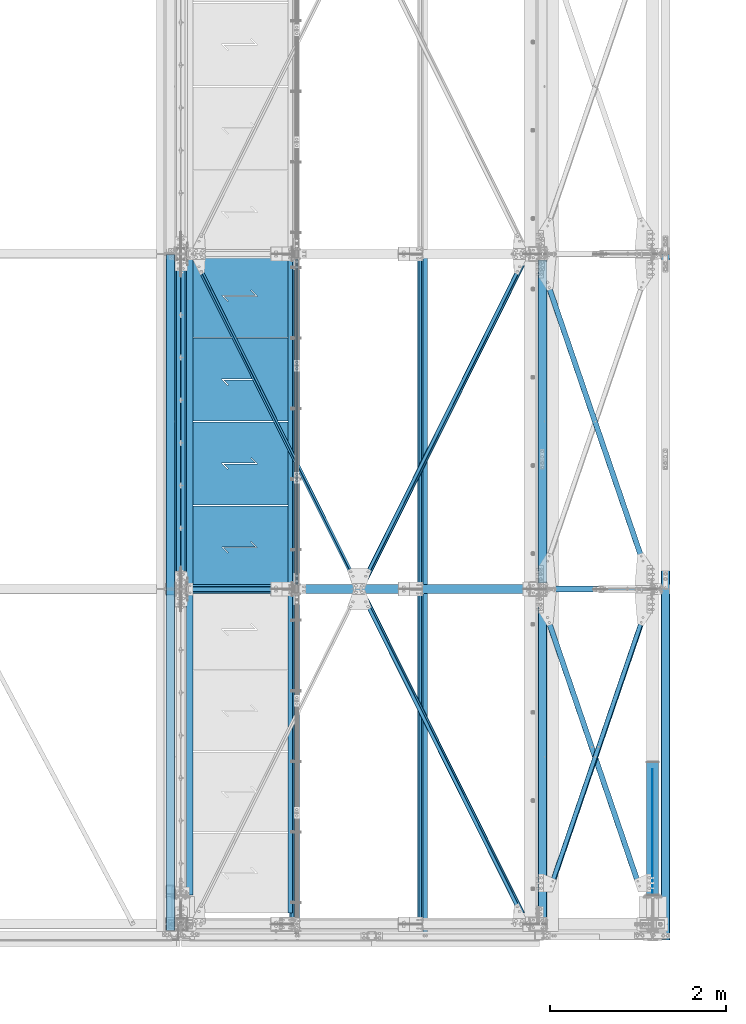
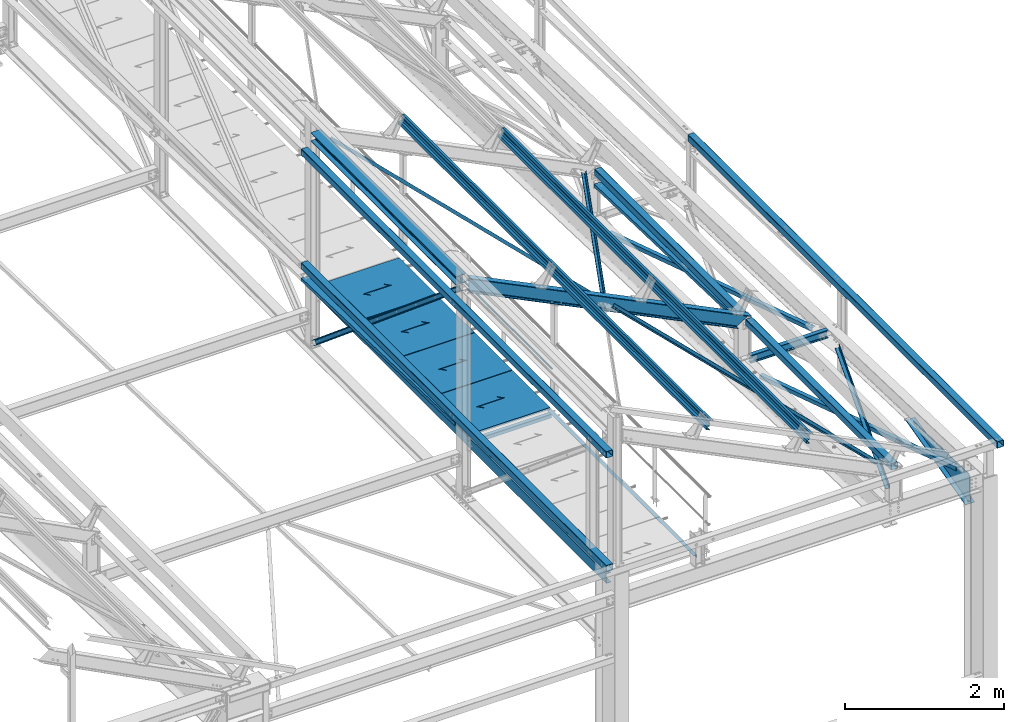
# One storey, part 55 of 496: 27 beams, 3 members, 29 elements without a shape of their own.
"""IFC2X3 building model written with IfcOpenShell, lengths in millimetres."""

from ifc_helpers import new_model, si_unit, frame, origin_with_axes, origin_2d_with_axis, place, context, subcontext, project, spatial, polyline, rectangle, hollow_rectangle, hollow_circle, i_section, l_section, u_section, outline, extrude, boolean, clip, halfspace, material, type_object, element, aggregate, save


model = new_model("IFC2X3")

# Units and contexts
model_context = context("Model", 3, precision=1e-05, world=origin_with_axes())
body_context = subcontext(model_context, "Body", "Model", "MODEL_VIEW")
ifc_project = project(units=[si_unit("LENGTHUNIT", "METRE", prefix="MILLI"), si_unit("AREAUNIT", "SQUARE_METRE"), si_unit("VOLUMEUNIT", "CUBIC_METRE"), si_unit("MASSUNIT", "GRAM", prefix="KILO"), si_unit("TIMEUNIT", "SECOND"), si_unit("PLANEANGLEUNIT", "RADIAN"), si_unit("SOLIDANGLEUNIT", "STERADIAN"), si_unit("THERMODYNAMICTEMPERATUREUNIT", "DEGREE_CELSIUS"), si_unit("LUMINOUSINTENSITYUNIT", "LUMEN")], contexts=[model_context])

# Site, building, storey
site_placement = place(None, origin_with_axes())
site = spatial("IfcSite", under=ifc_project, at=site_placement, CompositionType="ELEMENT")
building_placement = place(site_placement, origin_with_axes())
building = spatial("IfcBuilding", under=site, at=building_placement, Name="Undefined", CompositionType="ELEMENT")
storey_placement = place(building_placement, origin_with_axes())
storey = spatial("IfcBuildingStorey", under=building, at=storey_placement, Name="Undefined", CompositionType="ELEMENT", Elevation=0.0)

# Assembly, beam
assembly_1_placement = place(storey_placement, origin_with_axes())
assembly_1 = element("IfcElementAssembly", 1, at=assembly_1_placement, inside=storey, Name="SUPPORT", AssemblyPlace="NOTDEFINED", PredefinedType="NOTDEFINED")
ifc_material_1 = material(Name="Undefined/S235-E24")
beam_type_1 = type_object("IfcBeamType", PredefinedType="NOTDEFINED")
beam_1_placement = place(assembly_1_placement, frame((35521.4917137484, 7595.00000000005, 8075.0), z_axis=(-1.0, 0.0, 0.0), x_axis=(0.0, -1.0, 0.0)))
beam_1 = element("IfcBeam", 2, at=beam_1_placement, type_object=beam_type_1, material=ifc_material_1, Name="SUPPORT", context=body_context, shape_type="SweptSolid", body=[
    extrude(l_section(Depth=50.0, Width=50.0, Thickness=5.0, FilletRadius=7.0, EdgeRadius=3.5, at=origin_2d_with_axis()), frame((7469.99982384897, 0.0, 0.0), z_axis=(-1.0, 0.0, 0.0), x_axis=(0.0, -1.0, 0.0)), (0.0, 0.0, 1.0), 7470.0),
])
aggregate(assembly_1, [beam_1])

assembly_2_placement = place(storey_placement, origin_with_axes())
assembly_2 = element("IfcElementAssembly", 3, at=assembly_2_placement, inside=storey, AssemblyPlace="NOTDEFINED", PredefinedType="NOTDEFINED")
beam_2_placement = place(assembly_2_placement, frame((36314.0683436222, 3798.78791014463, 9506.75815228891), z_axis=(0.441221071222121, 0.0, 0.897398443451739), x_axis=(-0.435090904226981, 0.874605246456225, 0.213919536111583)))
beam_2 = element("IfcBeam", 4, at=beam_2_placement, type_object=beam_type_1, material=ifc_material_1, context=body_context, shape_type="Clipping", body=[
    clip(clip(extrude(l_section(Depth=50.0, Width=50.0, Thickness=5.0, FilletRadius=7.0, EdgeRadius=3.5, at=origin_2d_with_axis()), frame((4262.41841030255, -3.81543762183061e-12, 2.36611752985202e-13), z_axis=(-1.0, 0.0, 0.0), x_axis=(0.0, -1.0, 0.0)), (0.0, 0.0, 1.0), 4180.02), halfspace(frame((4208.92638047702, -25.0003728847478, -24.9999967013282), z_axis=(-1.0, 0.0, 0.0), x_axis=(0.0, 1.0, 0.0)), True)), halfspace(frame((135.8912948661, 24.9996600047416, -24.9993739036763), z_axis=(1.0, 0.0, 0.0), x_axis=(0.0, -1.0, 0.0)), True)),
])
aggregate(assembly_2, [beam_2])

assembly_3_placement = place(storey_placement, origin_with_axes())
assembly_3 = element("IfcElementAssembly", 5, at=assembly_3_placement, inside=storey, AssemblyPlace="NOTDEFINED", PredefinedType="NOTDEFINED")
beam_3_placement = place(assembly_3_placement, frame((38208.3828948081, 7598.78791190582, 8575.3867828065), z_axis=(0.441221071222121, 0.0, 0.897398443451739), x_axis=(-0.435090878201922, -0.874605259405945, 0.2139195360993)))
beam_3 = element("IfcBeam", 6, at=beam_3_placement, type_object=beam_type_1, material=ifc_material_1, context=body_context, shape_type="Clipping", body=[
    clip(clip(extrude(l_section(Depth=50.0, Width=50.0, Thickness=5.0, FilletRadius=7.0, EdgeRadius=3.5, at=origin_2d_with_axis()), frame((4267.3912059857, -3.69720075674132e-12, -3.63797880709171e-12), z_axis=(-1.0, 0.0, 0.0), x_axis=(0.0, -1.0, 0.0)), (0.0, 0.0, 1.0), 4189.97), halfspace(frame((4208.9260018769, 24.9996561668268, -24.9993340680921), z_axis=(1.0, 0.0, 0.0), x_axis=(0.0, -1.0, 0.0)), False)), halfspace(frame((135.890938227767, -25.0005331304928, -24.9987602459332), z_axis=(1.0, 0.0, 0.0), x_axis=(0.0, 0.0, 1.0)), True)),
])
aggregate(assembly_3, [beam_3])

assembly_4_placement = place(storey_placement, origin_with_axes())
assembly_4 = element("IfcElementAssembly", 7, at=assembly_4_placement, inside=storey, AssemblyPlace="NOTDEFINED", PredefinedType="NOTDEFINED")
beam_4_placement = place(assembly_4_placement, frame((38208.3828950162, 1.21208402601405, 8575.38678262109), z_axis=(-0.784869552886434, -0.484835707091843, 0.385893925944167), x_axis=(-0.435090904226981, 0.874605246456225, 0.213919536111583)))
beam_4 = element("IfcBeam", 8, at=beam_4_placement, type_object=beam_type_1, material=ifc_material_1, context=body_context, shape_type="Clipping", body=[
    clip(clip(extrude(l_section(Depth=50.0, Width=50.0, Thickness=5.0, FilletRadius=7.0, EdgeRadius=3.5, at=origin_2d_with_axis()), frame((4267.3918308939, 7.27595761418343e-12, -3.55331749931678e-13), z_axis=(-1.0, 0.0, 0.0), x_axis=(0.0, -1.0, 0.0)), (0.0, 0.0, 1.0), 4189.97), halfspace(frame((4208.92662626581, 24.9993342768721, -25.0000000990476), z_axis=(1.0, 0.0, 0.0), x_axis=(0.0, -1.0, 0.0)), False)), halfspace(frame((135.89147841968, 24.9987115401746, 24.9999250151195), z_axis=(1.0, 0.0, 0.0), x_axis=(0.0, 0.0, -1.0)), True)),
])
aggregate(assembly_4, [beam_4])

assembly_5_placement = place(storey_placement, origin_with_axes())
assembly_5 = element("IfcElementAssembly", 9, at=assembly_5_placement, inside=storey, AssemblyPlace="NOTDEFINED", PredefinedType="NOTDEFINED")
beam_type_2 = type_object("IfcBeamType", PredefinedType="NOTDEFINED")
beam_5_placement = place(assembly_5_placement, frame((39627.1613894349, 3796.01336444876, 7774.62276540689), z_axis=(0.946212867827137, 0.323385100940919, -0.0101629349981538), x_axis=(-0.323544727855661, 0.945746015578088, -0.0297200789867413)))
beam_5 = element("IfcBeam", 10, at=beam_5_placement, type_object=beam_type_2, material=ifc_material_1, context=body_context, shape_type="Clipping", body=[
    clip(clip(extrude(l_section(Depth=60.0, Width=60.0, Thickness=6.0, FilletRadius=8.0, EdgeRadius=4.0, at=origin_2d_with_axis()), frame((3750.95282930701, -8.83467238051806e-13, -7.58320368982886e-12), z_axis=(-1.0, 0.0, 0.0), x_axis=(0.0, -1.0, 0.0)), (0.0, 0.0, 1.0), 3483.91), halfspace(frame((3710.26461472647, 59.9991086554573, -29.9999875898502), z_axis=(-0.999999999997803, 2.09199999990344e-06, -1.31999999818056e-07), x_axis=(1.69800000215235e-06, 0.999999999998558, 0.0)), True)), halfspace(frame((307.727703394248, 60.0042625908254, 29.9999876960428), z_axis=(0.999999999998558, -1.69800000185205e-06, 0.0), x_axis=(1.69800000215235e-06, 0.999999999998558, 0.0)), True)),
])
aggregate(assembly_5, [beam_5])

assembly_6_placement = place(storey_placement, origin_with_axes())
assembly_6 = element("IfcElementAssembly", 11, at=assembly_6_placement, inside=storey, AssemblyPlace="NOTDEFINED", PredefinedType="NOTDEFINED")
beam_6_placement = place(assembly_6_placement, frame((39627.161389494, -3.98559414563732, 7894.04752087023), z_axis=(0.946212867827137, 0.323385100940919, -0.0101629349981538), x_axis=(-0.323544755417773, 0.945745955238383, -0.0297216990074912)))
beam_6 = element("IfcBeam", 12, at=beam_6_placement, type_object=beam_type_2, material=ifc_material_1, context=body_context, shape_type="Clipping", body=[
    clip(clip(extrude(l_section(Depth=60.0, Width=60.0, Thickness=6.0, FilletRadius=8.0, EdgeRadius=4.0, at=origin_2d_with_axis()), frame((3750.95227309595, 0.0, 3.7963490282553e-13), z_axis=(-1.0, 0.0, 0.0), x_axis=(0.0, -1.0, 0.0)), (0.0, 0.0, 1.0), 3363.91), halfspace(frame((3710.26372269314, 60.0043479088472, -30.000010124204), z_axis=(-0.99999999999782, -2.08799998896818e-06, 0.0), x_axis=(-1.15500000027281e-06, 0.999999999999333, 0.0)), True)), halfspace(frame((427.727369752653, 60.0002311482685, 29.9999514228402), z_axis=(0.999999999997803, 2.09200000135276e-06, 1.31999999817392e-07), x_axis=(-1.15500000027281e-06, 0.999999999999333, 0.0)), True)),
])
aggregate(assembly_6, [beam_6])

assembly_7_placement = place(storey_placement, origin_with_axes())
assembly_7 = element("IfcElementAssembly", 13, at=assembly_7_placement, inside=storey, AssemblyPlace="NOTDEFINED", PredefinedType="NOTDEFINED")
beam_7_placement = place(assembly_7_placement, frame((38332.8386386582, -1.91251005406912, 7960.01489811834), z_axis=(-0.946212870484427, 0.323385093165564, -0.0101629350051891), x_axis=(0.32354466896783, 0.945745967905964, -0.0297222369970447)))
beam_7 = element("IfcBeam", 14, at=beam_7_placement, type_object=beam_type_2, material=ifc_material_1, context=body_context, shape_type="Clipping", body=[
    clip(clip(extrude(l_section(Depth=60.0, Width=60.0, Thickness=6.0, FilletRadius=8.0, EdgeRadius=4.0, at=origin_2d_with_axis()), frame((3749.34856419133, 0.0, 3.16667539792858e-13), z_axis=(-1.0, 0.0, 0.0), x_axis=(0.0, -1.0, 0.0)), (0.0, 0.0, 1.0), 3360.71), halfspace(frame((3710.26373630886, -60.0043358212215, -30.0000327330927), z_axis=(0.999999999998558, -1.69800000185205e-06, 0.0), x_axis=(-1.69800000215235e-06, -0.999999999998558, 0.0)), False)), halfspace(frame((427.727444279331, -60.0002447770557, 29.9999646463839), z_axis=(-0.999999999997803, 2.09199999990344e-06, -1.31999999818056e-07), x_axis=(-1.69800000215235e-06, -0.999999999998558, 0.0)), False)),
])
aggregate(assembly_7, [beam_7])

assembly_8_placement = place(storey_placement, origin_with_axes())
assembly_8 = element("IfcElementAssembly", 15, at=assembly_8_placement, inside=storey, Name="LISSE", AssemblyPlace="NOTDEFINED", PredefinedType="NOTDEFINED")
beam_type_3 = type_object("IfcBeamType", PredefinedType="NOTDEFINED")
beam_8_placement = place(assembly_8_placement, frame((34163.5001162792, 3730.03454686984, 8413.05496432255), z_axis=(1.0, 0.0, 0.0), x_axis=(0.0, 0.999506445341009, -0.0314144190107172)))
beam_8 = element("IfcBeam", 16, at=beam_8_placement, type_object=beam_type_3, material=ifc_material_1, Name="LISSE", context=body_context, shape_type="SweptSolid", body=[
    extrude(u_section(Depth=100.0, FlangeWidth=50.0, WebThickness=4.0, FlangeThickness=4.0, at=origin_2d_with_axis()), frame((3864.8364307433, 0.0, 0.0), z_axis=(-1.0, 0.0, 0.0), x_axis=(0.0, -1.0, 0.0)), (0.0, 0.0, 1.0), 3864.84),
])
aggregate(assembly_8, [beam_8])

assembly_9_placement = place(storey_placement, origin_with_axes())
assembly_9 = element("IfcElementAssembly", 17, at=assembly_9_placement, inside=storey, Name="LISSE", AssemblyPlace="NOTDEFINED", PredefinedType="NOTDEFINED")
beam_9_placement = place(assembly_9_placement, frame((38380.0000000007, 3800.0, 8410.85601504986), z_axis=(1.0, 0.0, 0.0), x_axis=(0.0, 0.999506445341009, -0.0314144190107172)))
beam_9 = element("IfcBeam", 18, at=beam_9_placement, type_object=beam_type_3, material=ifc_material_1, Name="LISSE", context=body_context, shape_type="Clipping", body=[
    clip(clip(extrude(u_section(Depth=100.0, FlangeWidth=50.0, WebThickness=4.0, FlangeThickness=4.0, at=origin_2d_with_axis()), frame((3738.43154409699, 2.59405798515091e-14, 0.0), z_axis=(-1.0, 0.0, 0.0), x_axis=(0.0, -1.0, 0.0)), (0.0, 0.0, 1.0), 3536.42), halfspace(frame((3735.73414698921, 35.3226290313178, 49.9999999992579), z_axis=(-0.999506472307554, -0.0314135610096736, 0.0), x_axis=(0.0, 0.0, 1.0)), True)), halfspace(frame((202.484021196273, 35.5224298009161, 49.9999999992579), z_axis=(0.999506472307554, 0.0314135610096964, 0.0), x_axis=(0.0, 0.0, 1.0)), True)),
])
aggregate(assembly_9, [beam_9])

assembly_10_placement = place(storey_placement, origin_with_axes())
assembly_10 = element("IfcElementAssembly", 19, at=assembly_10_placement, inside=storey, Name="LISSE", AssemblyPlace="NOTDEFINED", PredefinedType="NOTDEFINED")
beam_type_4 = type_object("IfcBeamType", PredefinedType="NOTDEFINED")
beam_10_placement = place(assembly_10_placement, frame((34163.4999999633, -70.0000009811276, 10244.999999999), z_axis=(0.0, 0.0, -1.0), x_axis=(0.0, 1.0, 0.0)))
beam_10 = element("IfcBeam", 20, at=beam_10_placement, type_object=beam_type_4, material=ifc_material_1, Name="LISSE", context=body_context, shape_type="SweptSolid", body=[
    extrude(hollow_rectangle(XDim=100.0, YDim=100.0, WallThickness=4.0, InnerFilletRadius=4.0, OuterFilletRadius=8.0, at=origin_2d_with_axis()), frame((7664.99999999271, 0.0, 0.0), z_axis=(-1.0, 0.0, 0.0), x_axis=(0.0, -1.0, 0.0)), (0.0, 0.0, 1.0), 7665.0),
])
aggregate(assembly_10, [beam_10])

assembly_11_placement = place(storey_placement, origin_with_axes())
assembly_11 = element("IfcElementAssembly", 21, at=assembly_11_placement, inside=storey, Name="LISSE", AssemblyPlace="NOTDEFINED", PredefinedType="NOTDEFINED")
beam_11_placement = place(assembly_11_placement, frame((34163.5, -70.0, 8500.0), z_axis=(0.0, 0.0, 1.0), x_axis=(0.0, 1.0, 0.0)))
beam_11 = element("IfcBeam", 22, at=beam_11_placement, type_object=beam_type_4, material=ifc_material_1, Name="LISSE", context=body_context, shape_type="SweptSolid", body=[
    extrude(hollow_rectangle(XDim=100.0, YDim=100.0, WallThickness=4.0, InnerFilletRadius=4.0, OuterFilletRadius=8.0, at=origin_2d_with_axis()), frame((7664.99999999271, 0.0, 0.0), z_axis=(-1.0, 0.0, 0.0), x_axis=(0.0, -1.0, 0.0)), (0.0, 0.0, 1.0), 7665.0),
])
aggregate(assembly_11, [beam_11])

assembly_12_placement = place(storey_placement, origin_with_axes())
assembly_12 = element("IfcElementAssembly", 23, at=assembly_12_placement, inside=storey, Name="LISSE", AssemblyPlace="NOTDEFINED", PredefinedType="NOTDEFINED")
beam_12_placement = place(assembly_12_placement, frame((39775.0, -180.0, 8500.0), z_axis=(0.0, 0.0, 1.0), x_axis=(0.0, 1.0, 0.0)))
beam_12 = element("IfcBeam", 24, at=beam_12_placement, type_object=beam_type_4, material=ifc_material_1, Name="LISSE", context=body_context, shape_type="SweptSolid", body=[
    extrude(hollow_rectangle(XDim=100.0, YDim=100.0, WallThickness=4.0, InnerFilletRadius=4.0, OuterFilletRadius=8.0, at=origin_2d_with_axis()), frame((7775.00000003686, 0.0, 0.0), z_axis=(-1.0, 0.0, 0.0), x_axis=(0.0, -1.0, 0.0)), (0.0, 0.0, 1.0), 7775.0),
])
aggregate(assembly_12, [beam_12])

assembly_13_placement = place(storey_placement, origin_with_axes())
assembly_13 = element("IfcElementAssembly", 25, at=assembly_13_placement, inside=storey, Name="LISSE", AssemblyPlace="NOTDEFINED", PredefinedType="NOTDEFINED")
beam_13_placement = place(assembly_13_placement, frame((38380.0, 3870.0, 8500.0), z_axis=(0.0, 0.0, 1.0), x_axis=(0.0, 1.0, 0.0)))
beam_13 = element("IfcBeam", 26, at=beam_13_placement, type_object=beam_type_4, material=ifc_material_1, Name="LISSE", context=body_context, shape_type="SweptSolid", body=[
    extrude(hollow_rectangle(XDim=100.0, YDim=100.0, WallThickness=4.0, InnerFilletRadius=4.0, OuterFilletRadius=8.0, at=origin_2d_with_axis()), frame((3660.0, 0.0, 0.0), z_axis=(-1.0, 0.0, 0.0), x_axis=(0.0, -1.0, 0.0)), (0.0, 0.0, 1.0), 3660.0),
])
aggregate(assembly_13, [beam_13])

assembly_14_placement = place(storey_placement, origin_with_axes())
assembly_14 = element("IfcElementAssembly", 27, at=assembly_14_placement, inside=storey, Name="LISSE", AssemblyPlace="NOTDEFINED", PredefinedType="NOTDEFINED")
beam_14_placement = place(assembly_14_placement, frame((38380.0, 70.0, 8500.0), z_axis=(0.0, 0.0, 1.0), x_axis=(0.0, 1.0, 0.0)))
beam_14 = element("IfcBeam", 28, at=beam_14_placement, type_object=beam_type_4, material=ifc_material_1, Name="LISSE", context=body_context, shape_type="SweptSolid", body=[
    extrude(hollow_rectangle(XDim=100.0, YDim=100.0, WallThickness=4.0, InnerFilletRadius=4.0, OuterFilletRadius=8.0, at=origin_2d_with_axis()), frame((3660.0, 0.0, 0.0), z_axis=(-1.0, 0.0, 0.0), x_axis=(0.0, -1.0, 0.0)), (0.0, 0.0, 1.0), 3660.0),
])
aggregate(assembly_14, [beam_14])

assembly_15_placement = place(storey_placement, origin_with_axes())
assembly_15 = element("IfcElementAssembly", 29, at=assembly_15_placement, inside=storey, AssemblyPlace="NOTDEFINED", PredefinedType="NOTDEFINED")
beam_type_5 = type_object("IfcBeamType", PredefinedType="NOTDEFINED")
beam_15_placement = place(assembly_15_placement, frame((35536.4915949059, 4745.00031925659, 8115.0), z_axis=(0.0, 0.0, 1.0), x_axis=(-1.0, 0.0, 0.0)))
beam_15 = element("IfcBeam", 30, at=beam_15_placement, type_object=beam_type_5, material=ifc_material_1, context=body_context, shape_type="CSG", body=[
    boolean("DIFFERENCE", extrude(outline(polyline([(0.0, 0.0), (1179.99169921875, 0.0), (1179.99169921875, 940.0), (-9.39995516091585e-07, 940.0), (0.0, 0.0)])), frame((0.0, 0.0, -15.0), z_axis=(0.0, 0.0, 1.0), x_axis=(1.0, 0.0, 0.0)), (0.0, 0.0, 1.0), 30.0), extrude(outline(polyline([(0.0, 0.0), (9.99999999997453, 6.91215973347425e-11), (10.0000000004329, 75.8578643791443), (282.842712400121, -196.984848017997), (282.842712400743, -96.9848480190813), (272.842712400776, -96.9848480191613), (272.842712400299, -172.842712398218), (0.0, 100.0), (0.0, 0.0)])), frame((724.286946489367, 535.710676888644, -17.5), z_axis=(0.0, 0.0, 1.0), x_axis=(-0.707106781186457, -0.707106781186639, 0.0)), (0.0, 0.0, 1.0), 35.0)),
])
aggregate(assembly_15, [beam_15])

assembly_16_placement = place(storey_placement, origin_with_axes())
assembly_16 = element("IfcElementAssembly", 31, at=assembly_16_placement, inside=storey, AssemblyPlace="NOTDEFINED", PredefinedType="NOTDEFINED")
beam_16_placement = place(assembly_16_placement, frame((35536.4916006059, 5695.00031925659, 8115.0), z_axis=(0.0, 0.0, 1.0), x_axis=(-1.0, 0.0, 0.0)))
beam_16 = element("IfcBeam", 32, at=beam_16_placement, type_object=beam_type_5, material=ifc_material_1, context=body_context, shape_type="CSG", body=[
    boolean("DIFFERENCE", extrude(outline(polyline([(0.0, 0.0), (1179.99169921875, 0.0), (1179.99169921875, 940.0), (-9.39995516091585e-07, 940.0), (0.0, 0.0)])), frame((0.0, 0.0, -15.0), z_axis=(0.0, 0.0, 1.0), x_axis=(1.0, 0.0, 0.0)), (0.0, 0.0, 1.0), 30.0), extrude(outline(polyline([(0.0, 0.0), (9.99999999997453, 6.91215973347425e-11), (10.0000000004329, 75.8578643791443), (282.842712400121, -196.984848017997), (282.842712400743, -96.9848480190813), (272.842712400776, -96.9848480191613), (272.842712400299, -172.842712398218), (0.0, 100.0), (0.0, 0.0)])), frame((724.286946489367, 535.710676888644, -17.5), z_axis=(0.0, 0.0, 1.0), x_axis=(-0.707106781186457, -0.707106781186639, 0.0)), (0.0, 0.0, 1.0), 35.0)),
])
aggregate(assembly_16, [beam_16])

assembly_17_placement = place(storey_placement, origin_with_axes())
assembly_17 = element("IfcElementAssembly", 33, at=assembly_17_placement, inside=storey, AssemblyPlace="NOTDEFINED", PredefinedType="NOTDEFINED")
beam_17_placement = place(assembly_17_placement, frame((35536.4916063059, 6645.00031925659, 8115.0), z_axis=(0.0, 0.0, 1.0), x_axis=(-1.0, 0.0, 0.0)))
beam_17 = element("IfcBeam", 34, at=beam_17_placement, type_object=beam_type_5, material=ifc_material_1, context=body_context, shape_type="CSG", body=[
    boolean("DIFFERENCE", extrude(outline(polyline([(0.0, 0.0), (1179.99169921875, 0.0), (1179.99169921875, 940.0), (-9.39995516091585e-07, 940.0), (0.0, 0.0)])), frame((0.0, 0.0, -15.0), z_axis=(0.0, 0.0, 1.0), x_axis=(1.0, 0.0, 0.0)), (0.0, 0.0, 1.0), 30.0), extrude(outline(polyline([(0.0, 0.0), (9.99999999997453, 6.91215973347425e-11), (10.0000000004329, 75.8578643791443), (282.842712400121, -196.984848017997), (282.842712400743, -96.9848480190813), (272.842712400776, -96.9848480191613), (272.842712400299, -172.842712398218), (0.0, 100.0), (0.0, 0.0)])), frame((724.286946489367, 535.710676888644, -17.5), z_axis=(0.0, 0.0, 1.0), x_axis=(-0.707106781186457, -0.707106781186639, 0.0)), (0.0, 0.0, 1.0), 35.0)),
])
aggregate(assembly_17, [beam_17])

assembly_18_placement = place(storey_placement, origin_with_axes())
assembly_18 = element("IfcElementAssembly", 35, at=assembly_18_placement, inside=storey, AssemblyPlace="NOTDEFINED", PredefinedType="NOTDEFINED")
beam_18_placement = place(assembly_18_placement, frame((35536.4916120059, 7595.00032402585, 8115.0), z_axis=(0.0, 0.0, 1.0), x_axis=(-1.0, 0.0, 0.0)))
beam_18 = element("IfcBeam", 36, at=beam_18_placement, type_object=beam_type_5, material=ifc_material_1, context=body_context, shape_type="CSG", body=[
    boolean("DIFFERENCE", extrude(outline(polyline([(0.0, 0.0), (1179.99169921875, 0.0), (1179.99169921875, 940.0), (-9.39995516091585e-07, 940.0), (0.0, 0.0)])), frame((0.0, 0.0, -15.0), z_axis=(0.0, 0.0, 1.0), x_axis=(1.0, 0.0, 0.0)), (0.0, 0.0, 1.0), 30.0), extrude(outline(polyline([(0.0, 0.0), (9.99999999997453, 6.91215973347425e-11), (10.0000000004329, 75.8578643791443), (282.842712400121, -196.984848017997), (282.842712400743, -96.9848480190813), (272.842712400776, -96.9848480191613), (272.842712400299, -172.842712398218), (0.0, 100.0), (0.0, 0.0)])), frame((724.286946489367, 535.710676888644, -17.5), z_axis=(0.0, 0.0, 1.0), x_axis=(-0.707106781186457, -0.707106781186639, 0.0)), (0.0, 0.0, 1.0), 35.0)),
])
aggregate(assembly_18, [beam_18])

# Assembly, beams
assembly_19_placement = place(storey_placement, origin_with_axes())
assembly_19 = element("IfcElementAssembly", 37, at=assembly_19_placement, inside=storey, Name="TRAVERSE", AssemblyPlace="NOTDEFINED", PredefinedType="NOTDEFINED")
beam_type_6 = type_object("IfcBeamType", PredefinedType="NOTDEFINED")
beam_19_placement = place(assembly_19_placement, frame((39630.0000000007, 335.0, 7769.33890642295), z_axis=(-1.0, 0.0, 0.0), x_axis=(0.0, 0.999506556345274, -0.0314108870109058)))
beam_19 = element("IfcBeam", 38, at=beam_19_placement, type_object=beam_type_6, material=ifc_material_1, context=body_context, shape_type="SweptSolid", body=[
    extrude(outline(polyline([(0.942322762899387, 29.9851968112687), (30.0, 0.0), (1419.99999999984, -1.22432538773864e-09), (1423.27844149021, 22.6672111163732), (42.569691038819, 430.594491876205), (12.856783834807, 409.109499234062), (0.942322762899387, 29.9851968112687)])), frame((0.0, 0.0, -4.0), z_axis=(0.0, 0.0, 1.0), x_axis=(1.0, 0.0, 0.0)), (0.0, 0.0, 1.0), 8.0),
])
beam_type_7 = type_object("IfcBeamType", PredefinedType="NOTDEFINED")
beam_20_placement = place(assembly_19_placement, frame((39630.0, 1835.52522447158, 7717.38553692707), z_axis=(1.0, 0.0, 0.0), x_axis=(0.0, -0.967446195634957, -0.253076783904507)))
beam_20 = element("IfcBeam", 39, at=beam_20_placement, type_object=beam_type_7, material=ifc_material_1, context=body_context, shape_type="SweptSolid", body=[
    extrude(rectangle(XDim=10.0, YDim=135.0, at=origin_2d_with_axis()), frame((1549.7087562475, 0.0, 0.0), z_axis=(-1.0, 0.0, 0.0), x_axis=(0.0, -1.0, 0.0)), (0.0, 0.0, 1.0), 1549.71),
])
aggregate(assembly_19, [beam_19, beam_20])

# Assembly, beam
assembly_20_placement = place(storey_placement, origin_with_axes())
assembly_20 = element("IfcElementAssembly", 40, at=assembly_20_placement, inside=storey, Name="MAIN COURANTE", AssemblyPlace="NOTDEFINED", PredefinedType="NOTDEFINED")
beam_type_8 = type_object("IfcBeamType", PredefinedType="NOTDEFINED")
beam_21_placement = place(assembly_20_placement, frame((35593.9917170458, 7544.99999422589, 8673.80000207863), z_axis=(0.0, 0.0, 1.0), x_axis=(0.0, -1.0, 0.0)))
beam_21 = element("IfcBeam", 41, at=beam_21_placement, type_object=beam_type_8, material=ifc_material_1, Name="LISSE", context=body_context, shape_type="SweptSolid", body=[
    extrude(hollow_circle(Radius=13.44999981, WallThickness=2.0, at=origin_2d_with_axis()), frame((3690.00000000169, 3.69000323827281e-24, 0.0), z_axis=(-1.0, 0.0, 0.0), x_axis=(0.0, -1.0, 0.0)), (0.0, 0.0, 1.0), 3690.0),
])
aggregate(assembly_20, [beam_21])

assembly_21_placement = place(storey_placement, origin_with_axes())
assembly_21 = element("IfcElementAssembly", 42, at=assembly_21_placement, inside=storey, AssemblyPlace="NOTDEFINED", PredefinedType="NOTDEFINED")
ifc_material_2 = material(Name="Undefined/S275-E28")
beam_type_9 = type_object("IfcBeamType", Name="HEA140", PredefinedType="NOTDEFINED")
beam_22_placement = place(assembly_21_placement, frame((34283.5, 7525.0, 10489.5), z_axis=(0.0, 0.0, 1.0), x_axis=(0.0, -1.0, 0.0)))
beam_22 = element("IfcBeam", 43, at=beam_22_placement, type_object=beam_type_9, material=ifc_material_2, ObjectType="HEA140", context=body_context, shape_type="SweptSolid", body=[
    extrude(i_section(OverallWidth=140.0, OverallDepth=133.0, WebThickness=5.5, FlangeThickness=8.5, FilletRadius=12.0, at=origin_2d_with_axis()), frame((3650.0, 0.0, 0.0), z_axis=(-1.0, 0.0, 0.0), x_axis=(0.0, -1.0, 0.0)), (0.0, 0.0, 1.0), 3650.0),
])
aggregate(assembly_21, [beam_22])

assembly_22_placement = place(storey_placement, origin_with_axes())
assembly_22 = element("IfcElementAssembly", 44, at=assembly_22_placement, inside=storey, AssemblyPlace="NOTDEFINED", PredefinedType="NOTDEFINED")
beam_type_10 = type_object("IfcBeamType", PredefinedType="NOTDEFINED")
beam_23_placement = place(assembly_22_placement, frame((34381.500055484, 330.000000531133, 8025.0), z_axis=(0.0, 0.0, 1.0), x_axis=(0.0, 1.0, 0.0)))
beam_23 = element("IfcBeam", 45, at=beam_23_placement, type_object=beam_type_10, material=ifc_material_1, context=body_context, shape_type="SweptSolid", body=[
    extrude(u_section(Depth=150.0, FlangeWidth=70.0, WebThickness=5.0, FlangeThickness=5.0, at=origin_2d_with_axis()), frame((7265.00000099288, 0.0, 0.0), z_axis=(-1.0, 0.0, 0.0), x_axis=(0.0, -1.0, 0.0)), (0.0, 0.0, 1.0), 7265.0),
])
aggregate(assembly_22, [beam_23])

assembly_23_placement = place(storey_placement, origin_with_axes())
assembly_23 = element("IfcElementAssembly", 46, at=assembly_23_placement, inside=storey, Name="SHED", AssemblyPlace="NOTDEFINED", PredefinedType="NOTDEFINED")
beam_type_11 = type_object("IfcBeamType", PredefinedType="NOTDEFINED")
beam_24_placement = place(assembly_23_placement, frame((37020.1555051705, -154.999920381521, 9532.89989858766), z_axis=(0.441221071222121, 0.0, 0.897398443451739), x_axis=(0.0, 1.0, 0.0)))
beam_24 = element("IfcBeam", 47, at=beam_24_placement, type_object=beam_type_11, material=ifc_material_1, Name="SHED", context=body_context, shape_type="SweptSolid", body=[
    extrude(outline(polyline([(-27.9999999860338, 36.0000000101354), (-27.999999986052, 70.0000000101354), (28.0000000138389, 70.0000000101209), (28.0000000138425, 58.0000000101209), (26.5000000138534, 58.0000000101209), (26.5000000138352, 68.5000000101172), (-26.4999999860593, 68.5000000101354), (-26.4999999860338, 36.7000007730749), (-1.49999998607018, 15.6999998194005), (-1.49999998605563, -15.6999997991297), (-26.4999999859974, -36.7000007527895), (-26.4999999859829, -68.49999998985), (26.5000000139153, -68.4999999898646), (26.500000013908, -57.9999999898646), (28.0000000139116, -57.9999999898646), (28.0000000139153, -69.9999999898646), (-27.9999999859756, -69.99999998985), (-27.9999999859901, -35.99999998985), (-2.99999998605927, -14.9999999898646), (-2.9999999860629, 15.0000000101354), (-27.9999999860338, 36.0000000101354)])), frame((7750.00000000006, -3.63797880548905e-12, 0.0), z_axis=(-1.0, 0.0, 0.0), x_axis=(0.0, -1.0, 0.0)), (0.0, 0.0, 1.0), 7750.0),
])
aggregate(assembly_23, [beam_24])

assembly_24_placement = place(storey_placement, origin_with_axes())
assembly_24 = element("IfcElementAssembly", 48, at=assembly_24_placement, inside=storey, Name="SHED", AssemblyPlace="NOTDEFINED", PredefinedType="NOTDEFINED")
beam_25_placement = place(assembly_24_placement, frame((35571.322170931, -154.999920381521, 10245.2429542596), z_axis=(0.441221071222121, 0.0, 0.897398443451739), x_axis=(0.0, 1.0, 0.0)))
beam_25 = element("IfcBeam", 49, at=beam_25_placement, type_object=beam_type_11, material=ifc_material_1, Name="SHED", context=body_context, shape_type="SweptSolid", body=[
    extrude(outline(polyline([(-27.9999999860338, 36.0000000101354), (-27.999999986052, 70.0000000101354), (28.0000000138389, 70.0000000101209), (28.0000000138425, 58.0000000101209), (26.5000000138534, 58.0000000101209), (26.5000000138352, 68.5000000101172), (-26.4999999860593, 68.5000000101354), (-26.4999999860338, 36.7000007730749), (-1.49999998607018, 15.6999998194005), (-1.49999998605563, -15.6999997991297), (-26.4999999859974, -36.7000007527895), (-26.4999999859829, -68.49999998985), (26.5000000139153, -68.4999999898646), (26.500000013908, -57.9999999898646), (28.0000000139116, -57.9999999898646), (28.0000000139153, -69.9999999898646), (-27.9999999859756, -69.99999998985), (-27.9999999859901, -35.99999998985), (-2.99999998605927, -14.9999999898646), (-2.9999999860629, 15.0000000101354), (-27.9999999860338, 36.0000000101354)])), frame((7750.00000000006, -3.63797880548905e-12, 0.0), z_axis=(-1.0, 0.0, 0.0), x_axis=(0.0, -1.0, 0.0)), (0.0, 0.0, 1.0), 7750.0),
])
aggregate(assembly_24, [beam_25])

# Assembly, member
assembly_25_placement = place(storey_placement, origin_with_axes())
assembly_25 = element("IfcElementAssembly", 50, at=assembly_25_placement, inside=storey, AssemblyPlace="NOTDEFINED", PredefinedType="NOTDEFINED")
member_type_1 = type_object("IfcMemberType", Name="UPN80", PredefinedType="NOTDEFINED")
member_1_placement = place(assembly_25_placement, frame((34307.4999999937, 7599.99999999989, 7250.0), z_axis=(0.0, -0.640939616064268, -0.767591303076962), x_axis=(0.0, -0.767591727593998, 0.640939107660986)))
member_1 = element("IfcMember", 51, at=member_1_placement, type_object=member_type_1, material=ifc_material_2, ObjectType="UPN80", context=body_context, shape_type="Clipping", body=[
    clip(clip(extrude(u_section(Depth=80.0, FlangeWidth=45.0, WebThickness=6.0, FlangeThickness=8.0, FilletRadius=8.0, EdgeRadius=4.0, FlangeSlope=0.0798299857122373, at=origin_2d_with_axis()), frame((4910.05224962439, 0.0, 1.04649042213807e-12), z_axis=(-1.0, 0.0, 0.0), x_axis=(0.0, -1.0, 0.0)), (0.0, 0.0, 1.0), 4869.56), halfspace(frame((4830.54835301432, 27.49999999375, -39.9999989691332), z_axis=(-1.0, 0.0, 0.0), x_axis=(0.0, 1.0, 0.0)), True)), halfspace(frame((119.999999997919, 27.49999999375, -39.9999989691296), z_axis=(-1.0, 0.0, 0.0), x_axis=(0.0, 1.0, 0.0)), False)),
])
aggregate(assembly_25, [member_1])

assembly_26_placement = place(storey_placement, origin_with_axes())
assembly_26 = element("IfcElementAssembly", 52, at=assembly_26_placement, inside=storey, AssemblyPlace="NOTDEFINED", PredefinedType="NOTDEFINED")
member_2_placement = place(assembly_26_placement, frame((34252.4999999903, 3800.00000035527, 10422.9999997217), z_axis=(0.0, -0.640939616064268, -0.767591303076962), x_axis=(0.0, 0.767591303076962, -0.640939616064268)))
member_2 = element("IfcMember", 53, at=member_2_placement, type_object=member_type_1, material=ifc_material_2, ObjectType="UPN80", context=body_context, shape_type="Clipping", body=[
    clip(clip(extrude(u_section(Depth=80.0, FlangeWidth=45.0, WebThickness=6.0, FlangeThickness=8.0, FilletRadius=8.0, EdgeRadius=4.0, FlangeSlope=0.0798299857122373, at=origin_2d_with_axis()), frame((4910.05224962439, 0.0, 1.04649042213807e-12), z_axis=(-1.0, 0.0, 0.0), x_axis=(0.0, -1.0, 0.0)), (0.0, 0.0, 1.0), 4869.56), halfspace(frame((4830.54835301432, 27.49999999375, -39.9999989691332), z_axis=(1.0, 0.0, 0.0), x_axis=(0.0, -1.0, 0.0)), False)), halfspace(frame((119.999999997919, 27.49999999375, -39.9999989691296), z_axis=(1.0, 0.0, 0.0), x_axis=(0.0, -1.0, 0.0)), True)),
])
aggregate(assembly_26, [member_2])

# Assembly, beam
assembly_27_placement = place(storey_placement, origin_with_axes())
assembly_27 = element("IfcElementAssembly", 54, at=assembly_27_placement, inside=storey, AssemblyPlace="NOTDEFINED", PredefinedType="NOTDEFINED")
beam_type_12 = type_object("IfcBeamType", PredefinedType="NOTDEFINED")
beam_26_placement = place(assembly_27_placement, frame((34357.991943003, 3800.0, 8015.0), z_axis=(0.0, -1.0, 0.0), x_axis=(1.0, 0.0, 0.0)))
beam_26 = element("IfcBeam", 55, at=beam_26_placement, type_object=beam_type_12, material=ifc_material_1, context=body_context, shape_type="SweptSolid", body=[
    extrude(hollow_rectangle(XDim=60.0, YDim=60.0, WallThickness=3.0, InnerFilletRadius=3.0, OuterFilletRadius=6.0, at=origin_2d_with_axis()), frame((1181.99977105896, 0.0, 0.0), z_axis=(-1.0, 0.0, 0.0), x_axis=(0.0, -1.0, 0.0)), (0.0, 0.0, 1.0), 1182.0),
])
aggregate(assembly_27, [beam_26])

assembly_28_placement = place(storey_placement, origin_with_axes())
assembly_28 = element("IfcElementAssembly", 56, at=assembly_28_placement, inside=storey, AssemblyPlace="NOTDEFINED", PredefinedType="NOTDEFINED")
beam_type_13 = type_object("IfcBeamType", Name="IPE120", PredefinedType="NOTDEFINED")
beam_27_placement = place(assembly_28_placement, frame((38430.0, 3799.99999999992, 7870.55056696323), z_axis=(0.0, 0.031410887010906, 0.999506556345274), x_axis=(1.0, 0.0, 0.0)))
beam_27 = element("IfcBeam", 57, at=beam_27_placement, type_object=beam_type_13, material=ifc_material_2, ObjectType="IPE120", context=body_context, shape_type="SweptSolid", body=[
    extrude(i_section(OverallWidth=64.0, OverallDepth=120.0, WebThickness=4.400000095, FlangeThickness=6.300000191, FilletRadius=7.0, at=origin_2d_with_axis()), frame((1125.00000000002, 0.0, 0.0), z_axis=(-1.0, 0.0, 0.0), x_axis=(0.0, -1.0, 0.0)), (0.0, 0.0, 1.0), 1125.0),
])
aggregate(assembly_28, [beam_27])

# Assembly, member
assembly_29_placement = place(storey_placement, origin_with_axes())
assembly_29 = element("IfcElementAssembly", 58, at=assembly_29_placement, inside=storey, Name="TRAVERSE SHED", AssemblyPlace="NOTDEFINED", PredefinedType="NOTDEFINED")
member_type_2 = type_object("IfcMemberType", Name="IPE200", PredefinedType="NOTDEFINED")
member_3_placement = place(assembly_29_placement, frame((34305.8779065378, 3799.9999999968, 10466.2601489394), z_axis=(0.441221071222121, 0.0, 0.897398443451739), x_axis=(0.897398510539058, 0.0, -0.441220934773362)))
member_3 = element("IfcMember", 59, at=member_3_placement, type_object=member_type_2, material=ifc_material_2, Name="TRAVERSE SHED", ObjectType="IPE200", context=body_context, shape_type="Clipping", body=[
    clip(clip(extrude(i_section(OverallWidth=100.0, OverallDepth=200.0, WebThickness=5.599999905, FlangeThickness=8.5, FilletRadius=12.0, at=origin_2d_with_axis()), frame((4652.25219148987, 0.0, 0.0), z_axis=(-1.0, 0.0, 0.0), x_axis=(0.0, -1.0, 0.0)), (0.0, 0.0, 1.0), 4763.89), halfspace(frame((4421.9420250161, -3799.9999999968, -100.0), z_axis=(0.848887783899296, 0.0, -0.528573107854099), x_axis=(0.0, -1.0, 0.0)), False)), halfspace(frame((5.83309030194869, 3.19837843542485e-09, 102.867936075316), z_axis=(-0.89739851053906, 0.0, -0.44122093477336), x_axis=(0.0, -1.0, 0.0)), False)),
])
aggregate(assembly_29, [member_3])

save(model, "model.ifc")
